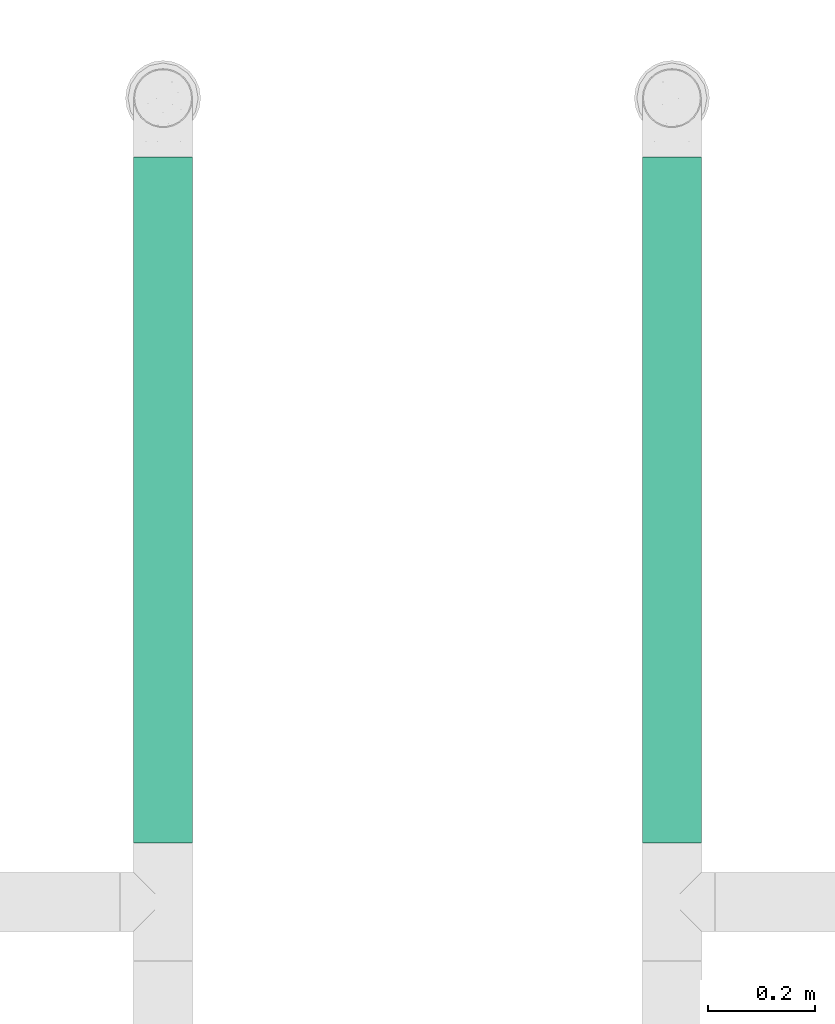
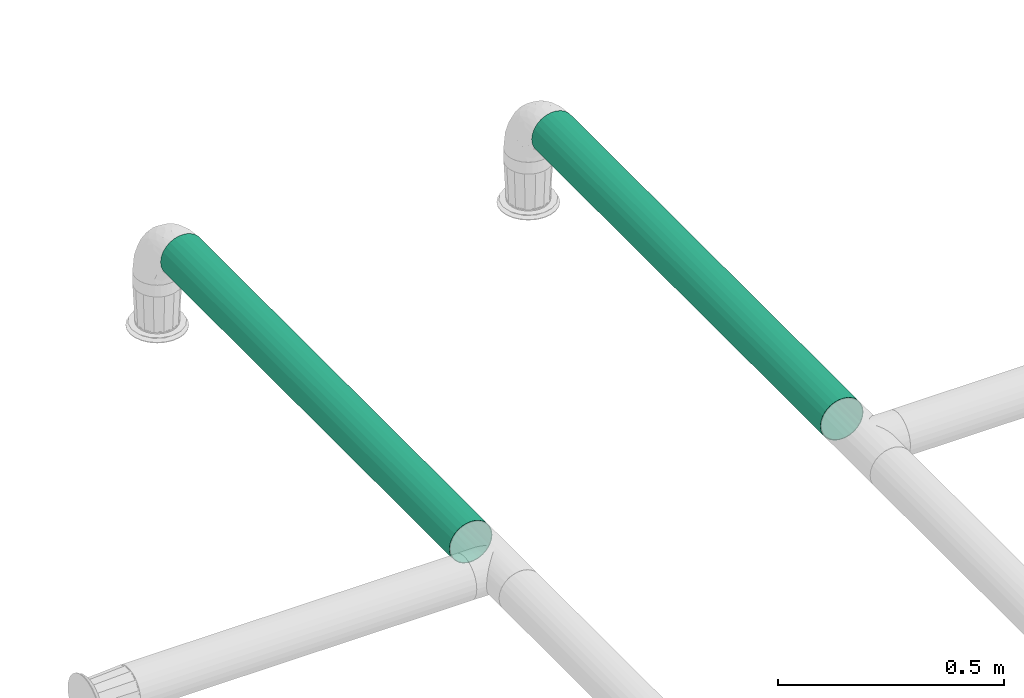
# One storey, part 3 of 123: 2 flow segments.
"""IFC2X3 building model written with IfcOpenShell, lengths in millimetres."""

from ifc_helpers import new_model, entity, si_unit, converted_unit, derived_unit, direction, frame, origin_with_axes, origin_2d_with_axis, place, context, subcontext, project, spatial, hollow_circle, extrude, source, transform, mapped, material, layer, layer_set, layer_usage, type_object, element, save


model = new_model("IFC2X3")

# Units and contexts
model_context = context("Model", 3, precision=1e-05, world=origin_with_axes(), true_north=direction((0.0, 1.0)))
body_context = subcontext(model_context, "Body", "Model", "MODEL_VIEW")
ifc_project = project(units=[si_unit("AREAUNIT", "SQUARE_METRE"), si_unit("VOLUMEUNIT", "CUBIC_METRE", prefix="DECI"), si_unit("TIMEUNIT", "SECOND"), si_unit("THERMODYNAMICTEMPERATUREUNIT", "DEGREE_CELSIUS"), si_unit("PRESSUREUNIT", "PASCAL"), si_unit("MASSUNIT", "GRAM", prefix="KILO"), si_unit("LENGTHUNIT", "METRE", prefix="MILLI"), si_unit("POWERUNIT", "WATT"), si_unit("ELECTRICCURRENTUNIT", "AMPERE"), si_unit("ELECTRICVOLTAGEUNIT", "VOLT"), derived_unit("VOLUMETRICFLOWRATEUNIT", [(si_unit("VOLUMEUNIT", "CUBIC_METRE", prefix="DECI"), 1), (si_unit("TIMEUNIT", "SECOND"), -1)]), derived_unit("LINEARVELOCITYUNIT", [(si_unit("LENGTHUNIT", "METRE"), 1), (si_unit("TIMEUNIT", "SECOND"), -1)]), derived_unit("MASSDENSITYUNIT", [(si_unit("MASSUNIT", "GRAM", prefix="KILO"), 1), (si_unit("VOLUMEUNIT", "CUBIC_METRE"), -1)]), converted_unit("PLANEANGLEUNIT", "DEGREE", entity("IfcRatioMeasure", 0.01745), si_unit("PLANEANGLEUNIT", "RADIAN"), dimensions=[0, 0, 0, 0, 0, 0, 0])], contexts=[model_context])

# Site, building, storey
site_placement = place(None, origin_with_axes())
site = spatial("IfcSite", under=ifc_project, at=site_placement, CompositionType="ELEMENT")
building_placement = place(site_placement, origin_with_axes())
building = spatial("IfcBuilding", under=site, at=building_placement, Name="mc-building", CompositionType="ELEMENT")
storey_placement = place(building_placement, origin_with_axes())
storey = spatial("IfcBuildingStorey", under=building, at=storey_placement, Name="1. Korrus", CompositionType="ELEMENT", Elevation=0.0)

# Flow segments
ifc_material = material(Name="FZ1")
ifc_layer = layer(ifc_material, 0.0)
ifc_layer_set = layer_set([ifc_layer], Name="FZ1")
ifc_layer_usage = layer_usage(ifc_layer_set, "AXIS1", "POSITIVE", 0.0)
duct_segment_type = type_object("IfcDuctSegmentType", PredefinedType="RIGIDSEGMENT")
shared_shape = source(origin_with_axes(), body_context, "Body", "SweptSolid", [
    extrude(hollow_circle(Radius=55.0, WallThickness=2.0, at=origin_2d_with_axis()), frame((0.0, 0.0, 0.0), z_axis=(1.0, 0.0, 0.0), x_axis=(0.0, 1.0, 0.0)), (0.0, 0.0, 1.0), 1278.0),
])
for number, where, z_axis, x_axis in (
    (1, (16466.11947, 3327.8145, 2445.0), (0.0, 0.0, 1.0), (0.0, 1.0, 0.0)),
    (2, (15517.82156, 3327.8145, 2445.0), (0.0, 0.0, 1.0), (0.0, 1.0, 0.0)),
):
    element("IfcFlowSegment", number, at=place(storey_placement, frame(where, z_axis=z_axis, x_axis=x_axis)), inside=storey, type_object=duct_segment_type, material=ifc_layer_usage, context=body_context, shape_type="MappedRepresentation", body=[
        mapped(shared_shape, transform((0.0, 0.0, 0.0), scale=1.0)),
    ])

save(model, "model.ifc")
